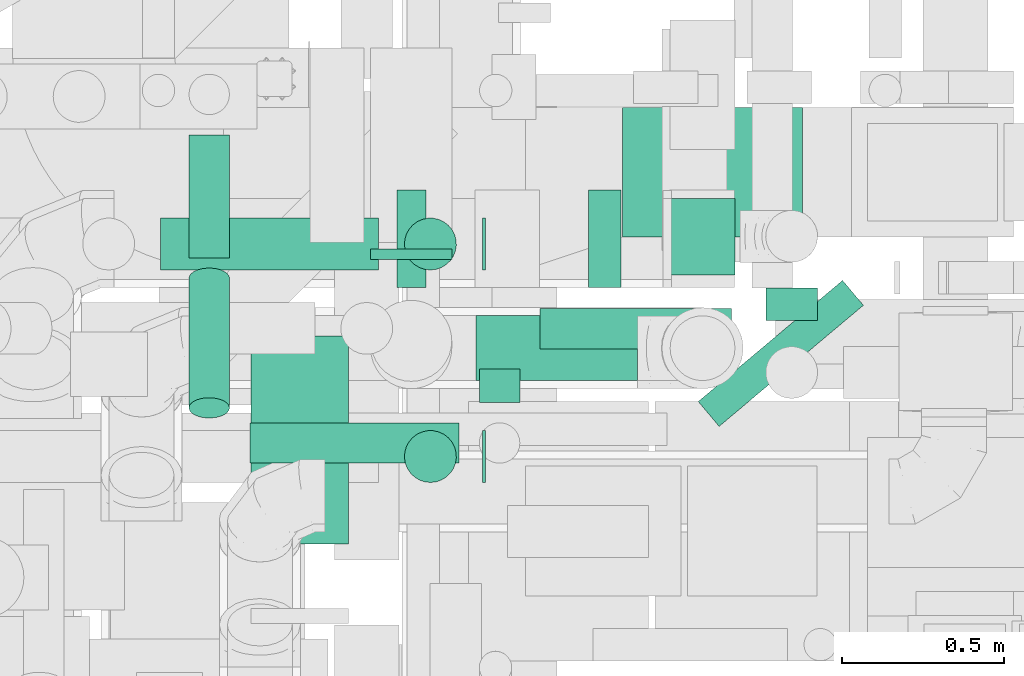
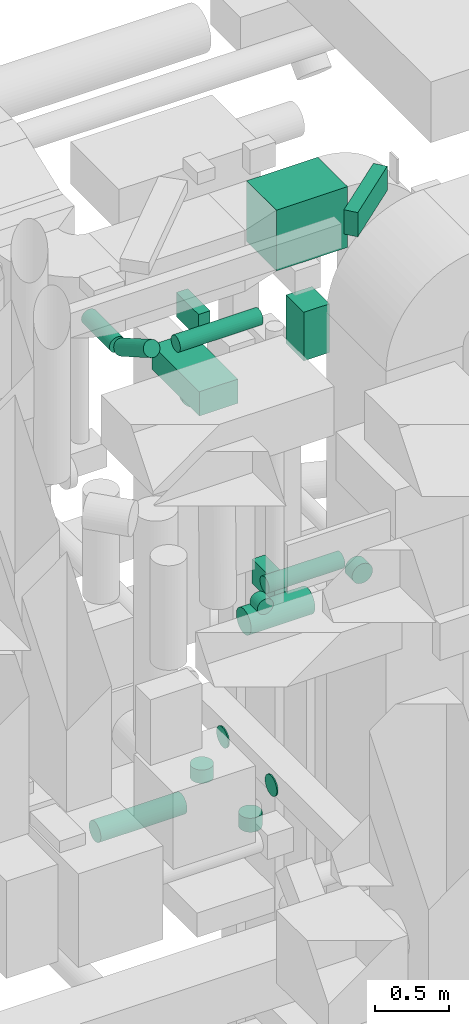
# One storey, part 193 of 337: 19 flow segments.
"""IFC2X3 building model written with IfcOpenShell, lengths in millimetres."""

from ifc_helpers import new_model, entity, si_unit, converted_unit, derived_unit, direction, frame, origin, origin_2d_with_axis, place, context, subcontext, project, spatial, rectangle, circle, extrude, type_object, element, save


model = new_model("IFC2X3")

# Units and contexts
model_context = context("Model", 3, precision=0.01, world=origin(), true_north=direction((6.12303176911189e-17, 1.0)))
body_context = subcontext(model_context, "Body", "Model", "MODEL_VIEW")
ifc_project = project(units=[si_unit("LENGTHUNIT", "METRE", prefix="MILLI"), si_unit("AREAUNIT", "SQUARE_METRE"), si_unit("VOLUMEUNIT", "CUBIC_METRE"), converted_unit("PLANEANGLEUNIT", "DEGREE", entity("IfcRatioMeasure", 0.0174532925199433), si_unit("PLANEANGLEUNIT", "RADIAN"), dimensions=[0, 0, 0, 0, 0, 0, 0]), si_unit("MASSUNIT", "GRAM", prefix="KILO"), derived_unit("MASSDENSITYUNIT", [(si_unit("MASSUNIT", "GRAM", prefix="KILO"), 1), (si_unit("LENGTHUNIT", "METRE"), -3)]), derived_unit("MOMENTOFINERTIAUNIT", [(si_unit("LENGTHUNIT", "METRE"), 4)]), si_unit("TIMEUNIT", "SECOND"), si_unit("FREQUENCYUNIT", "HERTZ"), si_unit("THERMODYNAMICTEMPERATUREUNIT", "DEGREE_CELSIUS"), derived_unit("THERMALTRANSMITTANCEUNIT", [(si_unit("MASSUNIT", "GRAM", prefix="KILO"), 1), (si_unit("THERMODYNAMICTEMPERATUREUNIT", "KELVIN"), -1), (si_unit("TIMEUNIT", "SECOND"), -3)]), derived_unit("VOLUMETRICFLOWRATEUNIT", [(si_unit("LENGTHUNIT", "METRE"), 3), (si_unit("TIMEUNIT", "SECOND"), -1)]), derived_unit("MASSFLOWRATEUNIT", [(si_unit("MASSUNIT", "GRAM", prefix="KILO"), 1), (si_unit("TIMEUNIT", "SECOND"), -1)]), derived_unit("ROTATIONALFREQUENCYUNIT", [(si_unit("TIMEUNIT", "SECOND"), -1)]), si_unit("ELECTRICCURRENTUNIT", "AMPERE"), si_unit("ELECTRICVOLTAGEUNIT", "VOLT"), si_unit("POWERUNIT", "WATT"), si_unit("FORCEUNIT", "NEWTON", prefix="KILO"), si_unit("ILLUMINANCEUNIT", "LUX"), si_unit("LUMINOUSFLUXUNIT", "LUMEN"), si_unit("LUMINOUSINTENSITYUNIT", "CANDELA"), derived_unit("USERDEFINED", [(si_unit("MASSUNIT", "GRAM", prefix="KILO"), -1), (si_unit("LENGTHUNIT", "METRE"), -2), (si_unit("TIMEUNIT", "SECOND"), 3), (si_unit("LUMINOUSFLUXUNIT", "LUMEN"), 1)]), derived_unit("LINEARVELOCITYUNIT", [(si_unit("LENGTHUNIT", "METRE"), 1), (si_unit("TIMEUNIT", "SECOND"), -1)]), si_unit("PRESSUREUNIT", "PASCAL"), derived_unit("USERDEFINED", [(si_unit("LENGTHUNIT", "METRE"), -2), (si_unit("MASSUNIT", "GRAM", prefix="KILO"), 1), (si_unit("TIMEUNIT", "SECOND"), -2)]), derived_unit("LINEARFORCEUNIT", [(si_unit("MASSUNIT", "GRAM", prefix="KILO"), 1), (si_unit("LENGTHUNIT", "METRE"), 1), (si_unit("TIMEUNIT", "SECOND"), -2), (si_unit("LENGTHUNIT", "METRE"), -1)]), derived_unit("PLANARFORCEUNIT", [(si_unit("MASSUNIT", "GRAM", prefix="KILO"), 1), (si_unit("LENGTHUNIT", "METRE"), 1), (si_unit("TIMEUNIT", "SECOND"), -2), (si_unit("LENGTHUNIT", "METRE"), -2)])], contexts=[model_context])

# Site, building, storey
site_placement = place(None, origin())
site = spatial("IfcSite", under=ifc_project, at=site_placement, CompositionType="ELEMENT")
building_placement = place(site_placement, origin())
building = spatial("IfcBuilding", under=site, at=building_placement, CompositionType="ELEMENT")
storey_placement = place(building_placement, origin())
storey = spatial("IfcBuildingStorey", under=building, at=storey_placement, CompositionType="ELEMENT", Elevation=0.0)

# Flow segments
duct_segment_type_1 = type_object("IfcDuctSegmentType", PredefinedType="NOTDEFINED")
flow_segment_1_placement = place(storey_placement, frame((51545.21, 12591.6, 31220.0)))
element("IfcFlowSegment", 1, at=flow_segment_1_placement, inside=storey, type_object=duct_segment_type_1, context=body_context, shape_type="SweptSolid", body=[
    extrude(rectangle(XDim=555.000017749885, YDim=400.0, at=origin_2d_with_axis()), frame((277.5, 200.0, 0.0), z_axis=(0.0, 0.0, 1.0), x_axis=(-1.0, 0.0, 0.0)), (0.0, 0.0, 1.0), 499.999999999999),
])
flow_segment_2_placement = place(storey_placement, frame((50399.86, 11646.25, 31000.0)))
element("IfcFlowSegment", 2, at=flow_segment_2_placement, inside=storey, type_object=duct_segment_type_1, context=body_context, shape_type="SweptSolid", body=[
    extrude(rectangle(XDim=639.646940000072, YDim=300.000000000001, at=origin_2d_with_axis()), frame((150.0, 319.82, 0.0), z_axis=(0.0, 0.0, 1.0), x_axis=(0.0, 1.0, 0.0)), (0.0, 0.0, 1.0), 199.999999999998),
])
flow_segment_3_placement = place(storey_placement, frame((50849.86, 12435.89, 31000.0)))
element("IfcFlowSegment", 3, at=flow_segment_3_placement, inside=storey, type_object=duct_segment_type_1, context=body_context, shape_type="SweptSolid", body=[
    extrude(rectangle(XDim=90.0000000000142, YDim=299.999999999999, at=origin_2d_with_axis()), frame((45.0, 150.0, 0.0)), (0.0, 0.0, 1.0), 199.999999999998),
])
flow_segment_4_placement = place(storey_placement, frame((51439.86, 12435.89, 28600.0)))
element("IfcFlowSegment", 4, at=flow_segment_4_placement, inside=storey, type_object=duct_segment_type_1, context=body_context, shape_type="SweptSolid", body=[
    extrude(rectangle(XDim=100.000000000012, YDim=299.999999999999, at=origin_2d_with_axis()), frame((50.0, 150.0, 0.0)), (0.0, 0.0, 1.0), 199.999999999998),
])
flow_segment_5_placement = place(storey_placement, frame((51778.49, 12007.97, 31750.0)))
element("IfcFlowSegment", 5, at=flow_segment_5_placement, inside=storey, type_object=duct_segment_type_1, context=body_context, shape_type="SweptSolid", body=[
    extrude(rectangle(XDim=580.672918430462, YDim=99.9999999999966, at=origin_2d_with_axis()), frame((254.55, 224.93, 0.0), z_axis=(0.0, 0.0, 1.0), x_axis=(0.766044443118978, 0.642787609686539, 0.0)), (0.0, 0.0, 1.0), 199.999999999998),
])
flow_segment_6_placement = place(storey_placement, frame((51691.36, 12474.0, 30500.0)))
element("IfcFlowSegment", 6, at=flow_segment_6_placement, inside=storey, type_object=duct_segment_type_1, context=body_context, shape_type="SweptSolid", body=[
    extrude(rectangle(XDim=237.012910000014, YDim=199.999999999998, at=origin_2d_with_axis()), frame((100.0, 118.51, 0.0), z_axis=(0.0, 0.0, 1.0), x_axis=(0.0, -1.0, 0.0)), (0.0, 0.0, 1.0), 399.999999999996),
])
duct_segment_type_2 = type_object("IfcDuctSegmentType", PredefinedType="NOTDEFINED")
for number, where in (
    (7, (51112.88, 11833.6, 27468.4)),
    (8, (51112.88, 12488.5, 27468.4)),
):
    element("IfcFlowSegment", number, at=place(storey_placement, frame(where)), inside=storey, type_object=duct_segment_type_2, context=body_context, shape_type="SweptSolid", body=[
        extrude(circle(Radius=80.0, at=origin_2d_with_axis()), frame((0.0, 81.6, 81.6), z_axis=(1.0, 0.0, 0.0), x_axis=(0.0, 1.0, 0.0)), (0.0, 0.0, 1.0), 10.0280876776039),
    ])
flow_segment_7_placement = place(storey_placement, frame((50121.09, 12488.5, 27038.4)))
element("IfcFlowSegment", 9, at=flow_segment_7_placement, inside=storey, type_object=duct_segment_type_2, context=body_context, shape_type="SweptSolid", body=[
    extrude(circle(Radius=80.0, at=origin_2d_with_axis()), frame((0.0, 81.6, 81.6), z_axis=(1.0, 0.0, 0.0), x_axis=(0.0, 1.0, 0.0)), (0.0, 0.0, 1.0), 671.787683086633),
])
flow_segment_8_placement = place(storey_placement, frame((50767.08, 12521.73, 30375.42)))
element("IfcFlowSegment", 10, at=flow_segment_8_placement, inside=storey, type_object=duct_segment_type_2, context=body_context, shape_type="SweptSolid", body=[
    extrude(circle(Radius=125.0, at=origin_2d_with_axis()), frame((126.6, 0.0, 126.6), z_axis=(0.0, 1.0, 0.0), x_axis=(-1.0, 0.0, 0.0)), (0.0, 0.0, 1.0), 33.0145254891762),
])
flow_segment_9_placement = place(storey_placement, frame((51093.68, 12147.45, 28602.74)))
element("IfcFlowSegment", 11, at=flow_segment_9_placement, inside=storey, type_object=duct_segment_type_2, context=body_context, shape_type="SweptSolid", body=[
    extrude(circle(Radius=100.0, at=origin_2d_with_axis()), frame((0.0, 101.6, 101.6), z_axis=(1.0, 0.0, 0.0), x_axis=(0.0, 1.0, 0.0)), (0.0, 0.0, 1.0), 498.036269129249),
])
flow_segment_10_placement = place(storey_placement, frame((51984.77, 12334.0, 28623.4)))
element("IfcFlowSegment", 12, at=flow_segment_10_placement, inside=storey, type_object=duct_segment_type_2, context=body_context, shape_type="SweptSolid", body=[
    extrude(circle(Radius=80.0, at=origin_2d_with_axis()), frame((81.6, 0.0, 81.6), z_axis=(0.0, 1.0, 0.0), x_axis=(1.0, 0.0, 0.0)), (0.0, 0.0, 1.0), 99.9166426163253),
])
flow_segment_11_placement = place(storey_placement, frame((51291.02, 12245.13, 28835.9)))
element("IfcFlowSegment", 13, at=flow_segment_11_placement, inside=storey, type_object=duct_segment_type_2, context=body_context, shape_type="SweptSolid", body=[
    extrude(circle(Radius=62.5, at=origin_2d_with_axis()), frame((0.0, 64.1, 64.1), z_axis=(1.0, 0.0, 0.0), x_axis=(0.0, 1.0, 0.0)), (0.0, 0.0, 1.0), 590.039493759005),
])
flow_segment_12_placement = place(storey_placement, frame((51101.92, 12081.82, 28835.9)))
element("IfcFlowSegment", 14, at=flow_segment_12_placement, inside=storey, type_object=duct_segment_type_2, context=body_context, shape_type="SweptSolid", body=[
    extrude(circle(Radius=62.5, at=origin_2d_with_axis()), frame((64.1, 0.0, 64.1), z_axis=(0.0, 1.0, 0.0), x_axis=(-1.0, 0.0, 0.0)), (0.0, 0.0, 1.0), 102.401003418293),
])
flow_segment_13_placement = place(storey_placement, frame((50396.02, 11892.73, 31345.9)))
element("IfcFlowSegment", 15, at=flow_segment_13_placement, inside=storey, type_object=duct_segment_type_2, context=body_context, shape_type="SweptSolid", body=[
    extrude(circle(Radius=62.5, at=origin_2d_with_axis()), frame((0.0, 64.1, 64.1), z_axis=(1.0, 0.0, 0.0), x_axis=(0.0, 0.499999999999995, 0.866025403784441)), (0.0, 0.0, 1.0), 645.000000000027),
])
flow_segment_14_placement = place(storey_placement, frame((50206.92, 12032.23, 31061.02)))
element("IfcFlowSegment", 16, at=flow_segment_14_placement, inside=storey, type_object=duct_segment_type_2, context=body_context, shape_type="SweptSolid", body=[
    extrude(circle(Radius=62.5, at=origin_2d_with_axis()), frame((64.1, 432.52, 55.72), z_axis=(0.0, -0.866025403784438, 0.500000000000001), x_axis=(1.0, 0.0, 0.0)), (0.0, 0.0, 1.0), 461.506350946121),
])
flow_segment_15_placement = place(storey_placement, frame((50206.92, 12527.25, 31035.9)))
element("IfcFlowSegment", 17, at=flow_segment_15_placement, inside=storey, type_object=duct_segment_type_2, context=body_context, shape_type="SweptSolid", body=[
    extrude(circle(Radius=62.5, at=origin_2d_with_axis()), frame((64.1, 0.0, 64.1), z_axis=(0.0, 1.0, 0.0), x_axis=(1.0, 0.0, 0.0)), (0.0, 0.0, 1.0), 379.019237886474),
])
flow_segment_16_placement = place(storey_placement, frame((50871.28, 12488.5, 27280.0)))
element("IfcFlowSegment", 18, at=flow_segment_16_placement, inside=storey, type_object=duct_segment_type_2, context=body_context, shape_type="SweptSolid", body=[
    extrude(circle(Radius=80.0, at=origin_2d_with_axis()), frame((81.6, 81.6, 0.0), z_axis=(0.0, 0.0, 1.0), x_axis=(0.0, -1.0, 0.0)), (0.0, 0.0, 1.0), 110.000000000036),
])
flow_segment_17_placement = place(storey_placement, frame((50871.28, 11833.6, 27274.71)))
element("IfcFlowSegment", 19, at=flow_segment_17_placement, inside=storey, type_object=duct_segment_type_2, context=body_context, shape_type="SweptSolid", body=[
    extrude(circle(Radius=80.0, at=origin_2d_with_axis()), frame((81.6, 81.6, 0.0), z_axis=(0.0, 0.0, 1.0), x_axis=(0.0, -1.0, 0.0)), (0.0, 0.0, 1.0), 115.29314741975),
])

save(model, "model.ifc")
